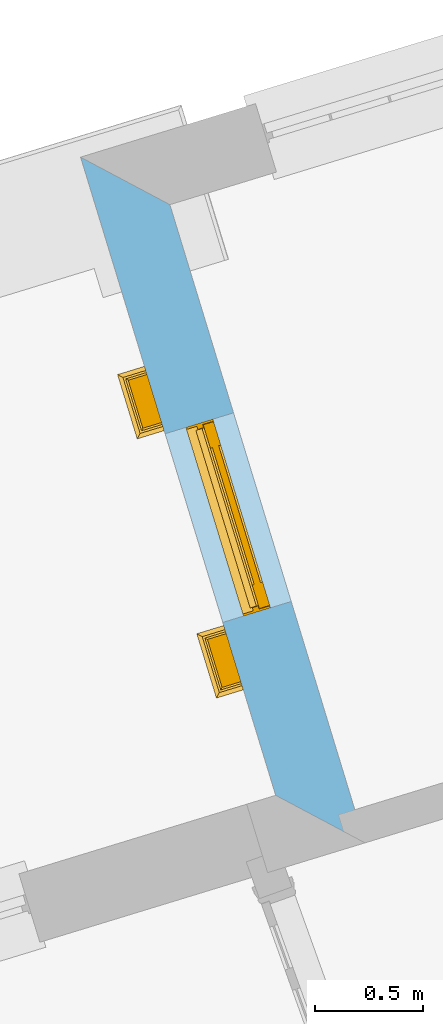
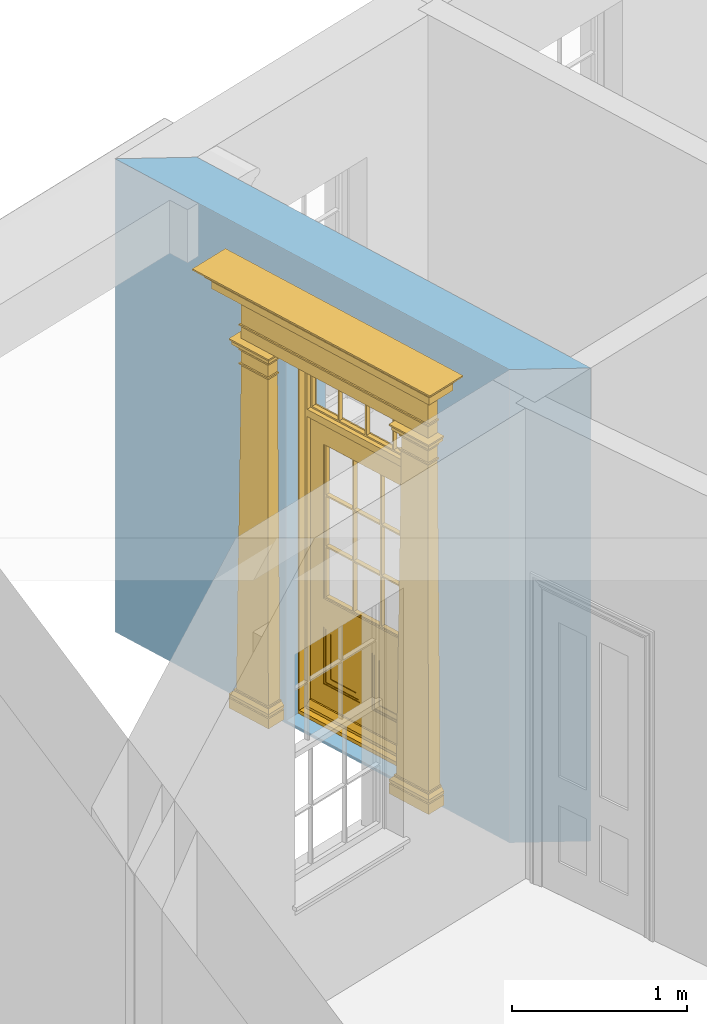
# One storey, part 6 of 10: 1 door, 1 opening, plus 1 element that does not belong to this part.
"""IFC2X3 building model written with IfcOpenShell, lengths in metres."""

from ifc_helpers import new_model, si_unit, frame, origin, place, context, subcontext, project, spatial, polyline, outline, extrude, faceted_brep, material, layer, layer_set, layer_usage, element, fill, save


model = new_model("IFC2X3")

# Units and contexts
model_context = context("Model", 3, world=origin())
body_context = subcontext(model_context, "Body", "Model", "MODEL_VIEW")
ifc_project = project(units=[si_unit("PLANEANGLEUNIT", "RADIAN"), si_unit("MASSUNIT", "GRAM", prefix="KILO"), si_unit("FORCEUNIT", "NEWTON", prefix="KILO"), si_unit("LENGTHUNIT", "METRE")], contexts=[model_context])

# Site, building, storey
site_placement = place(None, origin())
site = spatial("IfcSite", under=ifc_project, at=site_placement, CompositionType="ELEMENT")
building_placement = place(None, origin())
building = spatial("IfcBuilding", under=site, at=building_placement, Name="Building plot-9", CompositionType="ELEMENT")
storey_placement = place(None, frame((0.0, 0.0, 1.0)))
storey = spatial("IfcBuildingStorey", under=building, at=storey_placement, Name="Floor 0", CompositionType="ELEMENT", Elevation=1.0)

# Wall, opening, door
ifc_material = material(Name="Masonry")
ifc_layer = layer(ifc_material, 0.33, ventilated=False)
ifc_layer_set = layer_set([ifc_layer], Name="My Wall")
ifc_layer_usage = layer_usage(ifc_layer_set, "AXIS2", "NEGATIVE", 0.08)
wall_placement = place(storey_placement, origin())
wall = element("IfcWallStandardCase", 1, at=wall_placement, inside=storey, material=ifc_layer_usage, Name="exterior", context=body_context, shape_type="SweptSolid", body=[
    extrude(outline(polyline([(32.1406076281071, 21.1389745200244), (31.7285492158165, 21.3580814912976), (32.6284427963026, 18.4144306229796), (33.0405012085932, 18.1953236517064), (32.1406076281071, 21.1389745200244)])), origin(), (0.0, 0.0, 1.0), 3.3),
])
opening_placement = place(storey_placement, frame((0.0, 0.0, 0.02)))
opening = element("IfcOpeningElement", 2, at=opening_placement, cuts=wall, Name="Opening", ObjectType="Opening", context=body_context, shape_type="SweptSolid", body=[
    extrude(outline(polyline([(32.1185641190768, 20.0822998505183), (32.3846032271463, 19.21205667015), (32.7001859189282, 19.3085323906587), (32.4341468108587, 20.178775571027), (32.1185641190768, 20.0822998505183)])), origin(), (0.0, 0.0, 1.0), 2.545),
])
door_placement = place(storey_placement, frame((32.3576419158813, 20.1553875175704, 0.02), z_axis=(0.0, 0.0, 1.0), x_axis=(0.266039108069485, -0.870243180368337, 0.0)))
door = element("IfcDoor", 3, at=door_placement, inside=storey, Name="house entrance covered", OverallHeight=2.545, OverallWidth=0.91, context=body_context, shape_type="Brep", held_by="IfcProductRepresentation", body=[
    faceted_brep([(-0.305, -0.25, 2.895), (-0.335, -0.25, 2.915), (1.245, -0.25, 2.915), (1.215, -0.25, 2.895), (-0.315, -0.25, 2.895), (-0.335, -0.25, 2.925), (1.245, -0.25, 2.925), (1.225, -0.25, 2.895), (-0.295, -0.25, 2.885), (1.205, -0.25, 2.885), (-0.315, -0.37, 2.895), (-0.305, -0.36, 2.895), (-0.335, -0.39, 2.915), (-0.335, -0.39, 2.925), (-0.395, -0.25, 2.985), (1.305, -0.25, 2.985), (1.245, -0.39, 2.925), (1.245, -0.39, 2.915), (1.225, -0.37, 2.895), (1.215, -0.36, 2.895), (-0.305, -0.25, 2.885), (1.215, -0.25, 2.885), (-0.285, -0.25, 2.875), (1.195, -0.25, 2.875), (-0.305, -0.36, 2.885), (-0.395, -0.45, 2.925), (-0.395, -0.25, 2.925), (-0.405, -0.25, 2.995), (1.315, -0.25, 2.995), (1.305, -0.25, 2.925), (1.305, -0.45, 2.925), (1.215, -0.36, 2.885), (-0.295, -0.35, 2.885), (1.205, -0.35, 2.885), (-0.285, -0.34, 2.875), (1.195, -0.34, 2.875), (-0.275, -0.25, 2.865), (1.185, -0.25, 2.865), (-0.395, -0.45, 2.985), (-0.405, -0.25, 2.985), (-0.415, -0.25, 3.005), (1.325, -0.25, 3.005), (1.315, -0.25, 2.985), (1.305, -0.45, 2.985), (-0.285, -0.25, 2.865), (-0.285, -0.34, 2.865), (1.195, -0.34, 2.865), (1.195, -0.25, 2.865), (-0.275, -0.25, 2.675), (1.185, -0.25, 2.675), (-0.405, -0.46, 2.985), (-0.405, -0.46, 2.995), (-0.415, -0.47, 3.005), (-0.425, -0.25, 3.015), (1.335, -0.25, 3.015), (1.325, -0.47, 3.005), (1.315, -0.46, 2.995), (1.315, -0.46, 2.985), (-0.275, -0.33, 2.865), (1.185, -0.33, 2.865), (-0.275, -0.33, 2.675), (1.185, -0.33, 2.675), (-0.275, -0.25, 2.665), (1.185, -0.25, 2.665), (-0.425, -0.48, 3.005), (-0.425, -0.25, 3.005), (-0.445, -0.25, 3.046), (1.355, -0.25, 3.046), (1.335, -0.25, 3.005), (1.335, -0.48, 3.005), (-0.285, -0.34, 2.675), (-0.285, -0.25, 2.675), (1.195, -0.34, 2.675), (1.195, -0.25, 2.675), (-0.285, -0.25, 2.665), (1.195, -0.25, 2.665), (-0.015, -0.25, 2.575001), (0.925, -0.25, 2.575001), (-0.425, -0.48, 3.015), (-0.435, -0.25, 3.021), (-0.473, -0.25, 3.056), (1.383, -0.25, 3.056), (1.345, -0.25, 3.021), (1.335, -0.48, 3.015), (-0.285, -0.34, 2.665), (1.195, -0.34, 2.665), (-0.275, -0.33, 2.665), (1.185, -0.33, 2.665), (-0.275, -0.25, 2.575001), (1.185, -0.25, 2.575001), (-0.015, -0.33, 2.575001), (0.925, -0.33, 2.575001), (-0.435, -0.49, 3.021), (1.355, -0.5, 3.046), (-0.445, -0.5, 3.046), (1.345, -0.49, 3.021), (-0.473, -0.528, 3.056), (-0.473, -0.25, 3.066), (1.383, -0.25, 3.066), (1.383, -0.528, 3.056), (-0.275, -0.33, 2.575001), (1.185, -0.33, 2.575001), (-0.025, -0.25, 2.565001), (-0.315, -0.25, 2.565001), (1.225, -0.25, 2.565001), (0.935, -0.25, 2.565001), (-0.015, -0.38, 2.565001), (0.925, -0.25, 2.565001), (1.383, -0.528, 3.066), (-0.473, -0.528, 3.066), (-0.325, -0.25, 2.575001), (-0.325, -0.38, 2.575001), (1.235, -0.38, 2.575001), (1.235, -0.25, 2.575001), (-0.015, -0.25, 2.565001), (-0.035, -0.25, 2.535), (-0.305, -0.25, 2.535), (-0.325, -0.25, 2.565001), (1.235, -0.25, 2.565001), (0.945, -0.25, 2.535), (1.215, -0.25, 2.535), (-0.015, -0.38, 2.575001), (0.925, -0.38, 2.575001), (-0.325, -0.38, 2.565001), (1.235, -0.38, 2.565001), (-0.025, -0.37, 2.565001), (-0.025, -0.25, 2.535), (-0.305, -0.25, 2.525), (-0.035, -0.25, 2.525), (-0.315, -0.25, 2.535), (-0.315, -0.37, 2.565001), (1.225, -0.37, 2.565001), (0.935, -0.25, 2.535), (1.225, -0.25, 2.535), (1.215, -0.25, 2.525), (0.945, -0.25, 2.525), (0.935, -0.37, 2.565001), (0.925, -0.38, 2.565001), (-0.025, -0.37, 2.535), (-0.035, -0.36, 2.535), (-0.305, -0.36, 2.525), (-0.305, -0.36, 2.535), (-0.035, -0.36, 2.525), (-0.285, -0.25, 2.505), (-0.055, -0.25, 2.505), (-0.315, -0.37, 2.535), (1.225, -0.37, 2.535), (0.945, -0.36, 2.535), (0.935, -0.37, 2.535), (1.215, -0.36, 2.535), (1.215, -0.36, 2.525), (1.195, -0.25, 2.505), (0.965, -0.25, 2.505), (0.945, -0.36, 2.525), (-0.285, -0.34, 2.505), (-0.055, -0.34, 2.505), (-0.065, -0.25, 2.495), (-0.275, -0.25, 2.495), (1.195, -0.34, 2.505), (1.185, -0.25, 2.495), (0.975, -0.25, 2.495), (0.965, -0.34, 2.505), (-0.285, -0.25, 2.495), (-0.285, -0.34, 2.495), (-0.055, -0.25, 2.495), (-0.055, -0.34, 2.495), (-0.275, -0.25, 2.405), (-0.065, -0.25, 2.405), (1.195, -0.25, 2.495), (1.195, -0.34, 2.495), (1.185, -0.25, 2.405), (0.975, -0.25, 2.405), (0.965, -0.25, 2.495), (0.965, -0.34, 2.495), (-0.275, -0.33, 2.495), (-0.065, -0.33, 2.495), (-0.275, -0.33, 2.405), (-0.065, -0.33, 2.405), (-0.275, -0.25, 2.395), (-0.065, -0.25, 2.395), (1.185, -0.33, 2.495), (1.185, -0.33, 2.405), (1.185, -0.25, 2.395), (0.975, -0.25, 2.395), (0.975, -0.33, 2.405), (0.975, -0.33, 2.495), (-0.285, -0.25, 2.405), (-0.285, -0.34, 2.405), (-0.055, -0.34, 2.405), (-0.055, -0.25, 2.405), (-0.285, -0.25, 2.395), (-0.055, -0.25, 2.395), (-0.295, -0.25, 0.13), (-0.045, -0.25, 0.13), (1.195, -0.34, 2.405), (1.195, -0.25, 2.405), (1.195, -0.25, 2.395), (1.205, -0.25, 0.13), (0.955, -0.25, 0.13), (0.965, -0.25, 2.405), (0.965, -0.25, 2.395), (0.965, -0.34, 2.405), (-0.285, -0.34, 2.395), (-0.055, -0.34, 2.395), (-0.275, -0.33, 2.395), (-0.065, -0.33, 2.395), (-0.295, -0.35, 0.13), (-0.045, -0.35, 0.13), (-0.305, -0.25, 0.12), (-0.035, -0.25, 0.12), (1.195, -0.34, 2.395), (1.185, -0.33, 2.395), (1.205, -0.35, 0.13), (1.215, -0.25, 0.12), (0.945, -0.25, 0.12), (0.955, -0.35, 0.13), (0.975, -0.33, 2.395), (0.965, -0.34, 2.395), (-0.305, -0.25, 0.13), (-0.305, -0.36, 0.13), (-0.035, -0.25, 0.13), (-0.035, -0.36, 0.13), (-0.325, -0.25, 0.1), (-0.015, -0.25, 0.1), (1.215, -0.36, 0.13), (1.215, -0.25, 0.13), (1.235, -0.25, 0.1), (0.925, -0.25, 0.1), (0.945, -0.25, 0.13), (0.945, -0.36, 0.13), (-0.305, -0.36, 0.12), (-0.035, -0.36, 0.12), (-0.325, -0.38, 0.1), (-0.015, -0.38, 0.1), (-0.325, -0.25, 0.08), (-0.015, -0.25, 0.08), (1.215, -0.36, 0.12), (1.235, -0.38, 0.1), (1.235, -0.25, 0.08), (0.925, -0.25, 0.08), (0.925, -0.38, 0.1), (0.945, -0.36, 0.12), (-0.325, -0.38, 0.08), (-0.015, -0.38, 0.08), (-0.315, -0.25, 0.07), (-0.025, -0.25, 0.07), (1.235, -0.38, 0.08), (1.225, -0.25, 0.07), (0.935, -0.25, 0.07), (0.925, -0.38, 0.08), (-0.315, -0.37, 0.07), (-0.025, -0.37, 0.07), (-0.015, -0.25, 0.0), (-0.325, -0.25, 0.0), (1.225, -0.37, 0.07), (1.235, -0.25, 0.0), (0.925, -0.25, 0.0), (0.935, -0.37, 0.07), (-0.325, -0.25, 0.07), (-0.325, -0.38, 0.07), (-0.015, -0.38, 0.07), (-0.015, -0.25, 0.07), (-0.015, -0.38, 0.0), (-0.325, -0.38, 0.0), (1.235, -0.38, 0.07), (1.235, -0.25, 0.07), (1.235, -0.38, 0.0), (0.925, -0.38, 0.0), (0.925, -0.25, 0.07), (0.925, -0.38, 0.07), (0.885, -0.072, 0.025), (0.025, -0.072, 0.025), (0.025, -0.1, 0.025), (0.885, -0.1, 0.025), (0.9, -0.02, 0.025), (0.01, -0.02, 0.025), (0.9, -0.072, 0.025), (0.91, -0.02, 0.0), (0.0, -0.02, 0.0), (0.01, -0.072, 0.025), (0.9, -0.072, 2.07), (0.9, -0.02, 2.07), (0.885, -0.072, 2.055), (0.91, -0.02, 2.08), (0.01, -0.02, 2.07), (0.0, -0.02, 2.08), (0.01, -0.072, 2.07), (0.025, -0.072, 2.055), (0.455, -0.072, 2.07), (0.455, -0.02, 2.07), (0.455, -0.072, 2.055), (0.455, -0.02, 2.08), (0.455, -0.02, 2.105), (0.885, -0.02, 2.105), (0.025, -0.02, 2.105), (0.455, -0.04, 2.105), (0.885, -0.04, 2.105), (0.885, -0.02, 2.52), (0.91, -0.02, 2.545001), (0.025, -0.04, 2.105), (0.0, -0.02, 2.545001), (0.025, -0.02, 2.52), (0.885, -0.04, 2.52), (0.455, -0.02, 2.52), (0.455, -0.02, 2.545001), (0.025, -0.04, 2.52), (0.455, -0.04, 2.52), (0.0, -0.15, 0.0), (0.0, -0.15, 2.08), (0.91, -0.15, 0.0), (0.01, -0.15, 0.025), (0.01, -0.15, 2.08), (0.0, -0.15, 2.545001), (0.9, -0.15, 0.025), (0.91, -0.15, 2.08), (0.01, -0.1, 0.025), (0.01, -0.1, 2.055), (0.01, -0.15, 2.535), (0.455, -0.15, 2.545001), (0.9, -0.15, 2.08), (0.91, -0.15, 2.545001), (0.025, -0.1, 2.055), (0.01, -0.1, 2.105), (0.01, -0.1, 2.535), (0.455, -0.15, 2.535), (0.9, -0.1, 2.055), (0.9, -0.1, 0.025), (0.9, -0.15, 2.535), (0.025, -0.1, 2.105), (0.025, -0.1, 2.52), (0.455, -0.1, 2.535), (0.9, -0.1, 2.105), (0.885, -0.1, 2.055), (0.9, -0.1, 2.535), (0.455, -0.1, 2.055), (0.455, -0.1, 2.105), (0.025, -0.07, 2.105), (0.025, -0.07, 2.52), (0.455, -0.1, 2.52), (0.885, -0.1, 2.105), (0.885, -0.1, 2.52), (0.455, -0.07, 2.105), (0.035, -0.07, 2.51), (0.035, -0.07, 2.115), (0.455, -0.07, 2.52), (0.885, -0.07, 2.52), (0.885, -0.07, 2.105), (0.2475, -0.07, 2.115), (0.2375, -0.07, 2.115), (0.2375, -0.07, 2.51), (0.035, -0.04, 2.51), (0.035, -0.04, 2.115), (0.2475, -0.07, 2.51), (0.875, -0.07, 2.51), (0.875, -0.07, 2.115), (0.6725, -0.07, 2.115), (0.6625, -0.07, 2.115), (0.45, -0.07, 2.115), (0.2375, -0.04, 2.51), (0.2375, -0.04, 2.115), (0.45, -0.07, 2.51), (0.6625, -0.07, 2.51), (0.6725, -0.07, 2.51), (0.875, -0.04, 2.51), (0.875, -0.04, 2.115), (0.46, -0.07, 2.115), (0.45, -0.04, 2.115), (0.2475, -0.04, 2.115), (0.2475, -0.04, 2.51), (0.46, -0.07, 2.51), (0.45, -0.04, 2.51), (0.6725, -0.04, 2.51), (0.6725, -0.04, 2.115), (0.6625, -0.04, 2.51), (0.6625, -0.04, 2.115), (0.46, -0.04, 2.115), (0.46, -0.04, 2.51), (0.898, -0.07, 2.068), (0.898, -0.02, 2.068), (0.012, -0.02, 2.068), (0.012, -0.07, 2.068), (0.898, -0.07, 0.075), (0.898, -0.02, 0.027), (0.012, -0.02, 0.027), (0.012, -0.07, 0.075), (0.898, -0.07, 0.027), (0.012, -0.07, 0.027), (0.883, -0.07, 0.027), (0.883, -0.07, 0.075), (0.027, -0.07, 0.027), (0.027, -0.07, 0.075), (0.883, -0.08, 0.075), (0.883, -0.11, 0.045), (0.027, -0.11, 0.045), (0.027, -0.08, 0.075), (0.027, -0.11, 0.027), (0.883, -0.11, 0.027), (0.745, -0.05, 0.265), (0.545, -0.05, 0.265), (0.545, -0.055, 0.265), (0.745, -0.055, 0.265), (0.745, -0.05, 0.58), (0.545, -0.05, 0.58), (0.545, -0.055, 0.58), (0.515, -0.06, 0.235), (0.775, -0.06, 0.235), (0.745, -0.055, 0.58), (0.515, -0.06, 0.61), (0.515, -0.065, 0.235), (0.775, -0.065, 0.235), (0.775, -0.06, 0.61), (0.515, -0.065, 0.61), (0.785, -0.065, 0.225), (0.505, -0.065, 0.225), (0.775, -0.065, 0.61), (0.505, -0.065, 0.62), (0.785, -0.065, 0.62), (0.505, -0.07, 0.225), (0.785, -0.07, 0.225), (0.505, -0.07, 0.62), (0.785, -0.07, 0.62), (0.405, -0.07, 0.62), (0.405, -0.07, 0.225), (0.785, -0.07, 0.82), (0.125, -0.07, 0.82), (0.405, -0.065, 0.62), (0.405, -0.065, 0.225), (0.125, -0.07, 0.225), (0.785, -0.06, 0.82), (0.125, -0.06, 0.82), (0.125, -0.07, 0.62), (0.125, -0.065, 0.62), (0.395, -0.065, 0.61), (0.395, -0.065, 0.235), (0.125, -0.065, 0.225), (0.785, -0.07, 1.895), (0.558333, -0.06, 0.83), (0.351667, -0.06, 0.83), (0.125, -0.07, 1.895), (0.125, -0.06, 1.895), (0.785, -0.06, 1.895), (0.135, -0.065, 0.61), (0.395, -0.06, 0.61), (0.395, -0.06, 0.235), (0.135, -0.065, 0.235), (0.568333, -0.06, 0.83), (0.558333, -0.03, 0.83), (0.351667, -0.03, 0.83), (0.341667, -0.06, 0.83), (0.135, -0.06, 1.185), (0.135, -0.06, 1.53), (0.775, -0.06, 1.53), (0.775, -0.06, 1.185), (0.135, -0.06, 0.61), (0.365, -0.055, 0.58), (0.365, -0.055, 0.265), (0.135, -0.06, 0.235), (0.568333, -0.06, 1.175), (0.558333, -0.06, 1.175), (0.775, -0.06, 0.83), (0.558333, -0.03, 1.175), (0.785, -0.03, 0.82), (0.125, -0.03, 0.82), (0.351667, -0.03, 1.175), (0.351667, -0.06, 1.175), (0.341667, -0.06, 1.175), (0.135, -0.06, 0.83), (0.135, -0.06, 1.175), (0.135, -0.03, 1.185), (0.135, -0.03, 1.53), (0.135, -0.06, 1.54), (0.351667, -0.06, 1.885), (0.558333, -0.06, 1.885), (0.775, -0.03, 1.53), (0.775, -0.03, 1.185), (0.775, -0.06, 1.175), (0.775, -0.06, 1.54), (0.165, -0.055, 0.58), (0.365, -0.05, 0.58), (0.365, -0.05, 0.265), (0.165, -0.055, 0.265), (0.568333, -0.03, 0.83), (0.568333, -0.03, 1.175), (0.568333, -0.06, 1.185), (0.558333, -0.06, 1.185), (0.775, -0.03, 0.83), (0.785, -0.02, 0.82), (0.125, -0.02, 0.82), (0.341667, -0.03, 0.83), (0.341667, -0.03, 1.175), (0.351667, -0.06, 1.185), (0.341667, -0.06, 1.185), (0.135, -0.03, 0.83), (0.341667, -0.03, 1.185), (0.125, -0.03, 1.895), (0.341667, -0.03, 1.53), (0.341667, -0.06, 1.53), (0.135, -0.06, 1.885), (0.341667, -0.06, 1.54), (0.341667, -0.06, 1.885), (0.558333, -0.03, 1.885), (0.351667, -0.03, 1.885), (0.568333, -0.06, 1.885), (0.785, -0.03, 1.895), (0.568333, -0.03, 1.185), (0.568333, -0.06, 1.53), (0.568333, -0.03, 1.53), (0.568333, -0.06, 1.54), (0.775, -0.06, 1.885), (0.165, -0.05, 0.58), (0.165, -0.05, 0.265), (0.775, -0.03, 1.175), (0.558333, -0.06, 1.53), (0.351667, -0.03, 1.185), (0.558333, -0.03, 1.185), (0.505, -0.02, 0.62), (0.405, -0.02, 0.62), (0.125, -0.02, 1.895), (0.785, -0.02, 1.895), (0.351667, -0.06, 1.53), (0.135, -0.03, 1.175), (0.135, -0.03, 1.54), (0.341667, -0.03, 1.54), (0.135, -0.03, 1.885), (0.351667, -0.06, 1.54), (0.558333, -0.03, 1.54), (0.558333, -0.06, 1.54), (0.351667, -0.03, 1.54), (0.775, -0.03, 1.54), (0.568333, -0.03, 1.54), (0.775, -0.03, 1.885), (0.558333, -0.03, 1.53), (0.405, -0.02, 0.225), (0.505, -0.02, 0.225), (0.125, -0.02, 0.62), (0.785, -0.02, 0.62), (0.351667, -0.03, 1.53), (0.341667, -0.03, 1.885), (0.568333, -0.03, 1.885), (0.405, -0.025, 0.225), (0.405, -0.025, 0.62), (0.505, -0.025, 0.62), (0.505, -0.025, 0.225), (0.125, -0.025, 0.62), (0.785, -0.025, 0.62), (0.395, -0.025, 0.235), (0.395, -0.025, 0.61), (0.125, -0.02, 0.225), (0.125, -0.025, 0.225), (0.515, -0.025, 0.61), (0.515, -0.025, 0.235), (0.785, -0.02, 0.225), (0.785, -0.025, 0.225), (0.135, -0.025, 0.61), (0.775, -0.025, 0.61), (0.135, -0.025, 0.235), (0.395, -0.03, 0.235), (0.395, -0.03, 0.61), (0.515, -0.03, 0.61), (0.515, -0.03, 0.235), (0.775, -0.025, 0.235), (0.135, -0.03, 0.61), (0.775, -0.03, 0.61), (0.135, -0.03, 0.235), (0.365, -0.035, 0.265), (0.365, -0.035, 0.58), (0.545, -0.035, 0.58), (0.545, -0.035, 0.265), (0.775, -0.03, 0.235), (0.165, -0.035, 0.58), (0.745, -0.035, 0.58), (0.165, -0.035, 0.265), (0.365, -0.04, 0.58), (0.365, -0.04, 0.265), (0.545, -0.04, 0.58), (0.545, -0.04, 0.265), (0.745, -0.035, 0.265), (0.165, -0.04, 0.58), (0.745, -0.04, 0.58), (0.165, -0.04, 0.265), (0.745, -0.04, 0.265)], [[[0, 1, 2, 3]], [[0, 4, 1]], [[1, 5, 6, 2]], [[7, 3, 2]], [[8, 0, 3, 9]], [[10, 4, 0, 11]], [[12, 1, 4, 10]], [[1, 12, 13, 5]], [[5, 14, 15, 6]], [[6, 16, 17, 2]], [[7, 18, 19, 3]], [[2, 17, 18, 7]], [[8, 20, 0]], [[21, 9, 3]], [[22, 8, 9, 23]], [[11, 0, 20, 24]], [[10, 11, 19, 18]], [[12, 10, 18, 17]], [[25, 26, 5, 13]], [[13, 12, 17, 16]], [[5, 26, 14]], [[14, 27, 28, 15]], [[29, 6, 15]], [[29, 30, 16, 6]], [[3, 19, 31, 21]], [[24, 20, 8, 32]], [[21, 31, 33, 9]], [[32, 8, 22, 34]], [[9, 33, 35, 23]], [[36, 22, 23, 37]], [[11, 24, 31, 19]], [[38, 14, 26, 25]], [[25, 13, 16, 30]], [[14, 39, 27]], [[27, 40, 41, 28]], [[42, 15, 28]], [[15, 43, 30, 29]], [[24, 32, 33, 31]], [[34, 22, 44, 45]], [[32, 34, 35, 33]], [[23, 35, 46, 47]], [[36, 44, 22]], [[47, 37, 23]], [[48, 36, 37, 49]], [[50, 39, 14, 38]], [[38, 25, 30, 43]], [[51, 27, 39, 50]], [[52, 40, 27, 51]], [[40, 53, 54, 41]], [[41, 55, 56, 28]], [[42, 57, 43, 15]], [[28, 56, 57, 42]], [[45, 44, 36, 58]], [[34, 45, 46, 35]], [[47, 46, 59, 37]], [[60, 58, 36, 48]], [[59, 61, 49, 37]], [[62, 48, 49, 63]], [[50, 38, 43, 57]], [[51, 50, 57, 56]], [[64, 65, 40, 52]], [[52, 51, 56, 55]], [[40, 65, 53]], [[53, 66, 67, 54]], [[68, 41, 54]], [[68, 69, 55, 41]], [[45, 58, 59, 46]], [[58, 60, 61, 59]], [[70, 60, 48, 71]], [[61, 72, 73, 49]], [[71, 48, 62, 74]], [[49, 73, 75, 63]], [[76, 62, 63, 77]], [[78, 53, 65, 64]], [[64, 52, 55, 69]], [[53, 79, 66]], [[66, 80, 81, 67]], [[82, 54, 67]], [[54, 83, 69, 68]], [[60, 70, 72, 61]], [[84, 70, 71, 74]], [[72, 85, 75, 73]], [[86, 84, 74, 62]], [[85, 87, 63, 75]], [[76, 88, 62]], [[89, 77, 63]], [[90, 76, 77, 91]], [[92, 79, 53, 78]], [[93, 94, 92, 95]], [[64, 69, 83, 78]], [[94, 66, 79, 92]], [[80, 66, 94, 96]], [[80, 97, 98, 81]], [[99, 93, 67, 81]], [[82, 95, 83, 54]], [[67, 93, 95, 82]], [[92, 78, 83, 95]], [[70, 84, 85, 72]], [[84, 86, 87, 85]], [[100, 86, 62, 88]], [[87, 101, 89, 63]], [[88, 76, 102, 103]], [[77, 89, 104, 105]], [[76, 90, 106]], [[91, 77, 107]], [[86, 90, 91, 87]], [[108, 98, 97, 109]], [[109, 97, 80, 96]], [[98, 108, 99, 81]], [[86, 100, 90]], [[100, 88, 110, 111]], [[101, 87, 91]], [[89, 101, 112, 113]], [[76, 114, 102]], [[102, 115, 116, 103]], [[110, 88, 103, 117]], [[89, 113, 118, 104]], [[119, 105, 104, 120]], [[107, 77, 105]], [[90, 121, 106]], [[106, 114, 76]], [[107, 122, 91]], [[109, 96, 99, 108]], [[96, 94, 93, 99]], [[111, 121, 90, 100]], [[110, 117, 123, 111]], [[122, 112, 101, 91]], [[118, 113, 112, 124]], [[102, 114, 106, 125]], [[102, 126, 115]], [[127, 116, 115, 128]], [[103, 116, 129]], [[117, 103, 130, 123]], [[104, 118, 124, 131]], [[119, 132, 105]], [[104, 133, 120]], [[120, 134, 135, 119]], [[107, 105, 136, 137]], [[106, 121, 111, 123]], [[107, 137, 122]], [[122, 137, 124, 112]], [[130, 125, 106, 123]], [[126, 102, 125, 138]], [[115, 126, 138, 139]], [[116, 127, 140, 141]], [[128, 115, 139, 142]], [[143, 127, 128, 144]], [[129, 116, 141, 145]], [[103, 129, 145, 130]], [[136, 131, 124, 137]], [[133, 104, 131, 146]], [[132, 119, 147, 148]], [[105, 132, 148, 136]], [[120, 133, 146, 149]], [[134, 120, 149, 150]], [[134, 151, 152, 135]], [[119, 135, 153, 147]], [[138, 125, 130, 145]], [[141, 139, 138, 145]], [[127, 143, 154, 140]], [[142, 139, 141, 140]], [[144, 128, 142, 155]], [[156, 157, 143, 144]], [[136, 148, 146, 131]], [[147, 149, 146, 148]], [[147, 153, 150, 149]], [[151, 134, 150, 158]], [[159, 160, 152, 151]], [[135, 152, 161, 153]], [[143, 162, 163, 154]], [[140, 154, 155, 142]], [[164, 144, 155, 165]], [[166, 157, 156, 167]], [[157, 162, 143]], [[144, 164, 156]], [[158, 150, 153, 161]], [[168, 151, 158, 169]], [[159, 170, 171, 160]], [[172, 152, 160]], [[168, 159, 151]], [[152, 172, 173, 161]], [[174, 163, 162, 157]], [[155, 154, 163, 165]], [[164, 165, 175, 156]], [[157, 166, 176, 174]], [[167, 156, 175, 177]], [[178, 166, 167, 179]], [[158, 161, 173, 169]], [[169, 180, 159, 168]], [[170, 159, 180, 181]], [[170, 182, 183, 171]], [[160, 171, 184, 185]], [[173, 172, 160, 185]], [[174, 175, 165, 163]], [[186, 187, 176, 166]], [[174, 176, 177, 175]], [[177, 188, 189, 167]], [[178, 190, 186, 166]], [[167, 189, 191, 179]], [[192, 178, 179, 193]], [[185, 180, 169, 173]], [[181, 180, 185, 184]], [[194, 195, 170, 181]], [[196, 182, 170, 195]], [[182, 197, 198, 183]], [[199, 171, 183, 200]], [[201, 184, 171, 199]], [[190, 202, 187, 186]], [[177, 176, 187, 188]], [[191, 189, 188, 203]], [[204, 202, 190, 178]], [[191, 203, 205, 179]], [[178, 192, 206, 204]], [[193, 179, 205, 207]], [[208, 192, 193, 209]], [[181, 184, 201, 194]], [[210, 196, 195, 194]], [[210, 211, 182, 196]], [[211, 212, 197, 182]], [[197, 213, 214, 198]], [[183, 198, 215, 216]], [[217, 200, 183, 216]], [[199, 200, 217, 201]], [[202, 203, 188, 187]], [[204, 205, 203, 202]], [[192, 218, 219, 206]], [[204, 206, 207, 205]], [[220, 193, 207, 221]], [[208, 218, 192]], [[193, 220, 209]], [[222, 208, 209, 223]], [[217, 210, 194, 201]], [[216, 211, 210, 217]], [[212, 211, 216, 215]], [[212, 224, 225, 197]], [[225, 213, 197]], [[213, 226, 227, 214]], [[228, 198, 214]], [[198, 228, 229, 215]], [[218, 208, 230, 219]], [[221, 207, 206, 219]], [[209, 220, 221, 231]], [[208, 222, 232, 230]], [[223, 209, 231, 233]], [[234, 222, 223, 235]], [[224, 212, 215, 229]], [[213, 225, 224, 236]], [[226, 213, 236, 237]], [[226, 238, 239, 227]], [[214, 227, 240, 241]], [[228, 214, 241, 229]], [[231, 221, 219, 230]], [[234, 242, 232, 222]], [[233, 231, 230, 232]], [[235, 223, 233, 243]], [[244, 234, 235, 245]], [[229, 241, 236, 224]], [[241, 240, 237, 236]], [[246, 238, 226, 237]], [[238, 247, 248, 239]], [[227, 239, 249, 240]], [[234, 244, 250, 242]], [[243, 233, 232, 242]], [[245, 235, 243, 251]], [[252, 253, 244, 245]], [[240, 249, 246, 237]], [[247, 238, 246, 254]], [[255, 256, 248, 247]], [[239, 248, 257, 249]], [[258, 259, 250, 244]], [[242, 250, 251, 243]], [[251, 260, 261, 245]], [[262, 263, 253, 252]], [[253, 258, 244]], [[245, 261, 252]], [[254, 246, 249, 257]], [[264, 265, 247, 254]], [[266, 267, 256, 255]], [[268, 248, 256]], [[265, 255, 247]], [[269, 257, 248, 268]], [[258, 253, 263, 259]], [[251, 250, 259, 260]], [[252, 261, 260, 262]], [[259, 263, 262, 260]], [[254, 257, 269, 264]], [[255, 265, 264, 266]], [[266, 264, 269, 267]], [[268, 256, 267, 269]], [[270, 271, 272, 273]], [[271, 270, 274, 275]], [[276, 274, 270]], [[274, 277, 278, 275]], [[279, 271, 275]], [[280, 281, 274, 276]], [[276, 270, 282, 280]], [[281, 283, 277, 274]], [[284, 275, 278, 285]], [[286, 287, 271, 279]], [[275, 284, 286, 279]], [[280, 288, 289, 281]], [[282, 290, 288, 280]], [[281, 289, 291, 283]], [[285, 291, 289, 284]], [[286, 288, 290, 287]], [[284, 289, 288, 286]], [[283, 291, 292, 293]], [[294, 292, 291, 285]], [[293, 292, 295, 296]], [[283, 293, 297, 298]], [[299, 295, 292, 294]], [[294, 285, 300, 301]], [[296, 302, 297, 293]], [[297, 303, 304, 298]], [[305, 299, 294, 301]], [[300, 304, 303, 301]], [[302, 306, 303, 297]], [[301, 303, 306, 305]], [[285, 278, 307, 308]], [[309, 307, 278, 277]], [[307, 310, 311, 308]], [[285, 308, 312, 300]], [[307, 309, 313, 310]], [[314, 309, 277, 283]], [[315, 316, 311, 310]], [[312, 308, 311, 317]], [[312, 318, 304, 300]], [[319, 313, 309, 314]], [[310, 313, 273, 272]], [[320, 314, 283, 298]], [[272, 321, 316, 315]], [[322, 311, 316]], [[315, 310, 272]], [[317, 311, 322, 323]], [[317, 324, 318, 312]], [[298, 304, 318, 320]], [[313, 319, 325, 326]], [[327, 319, 314, 320]], [[326, 273, 313]], [[287, 321, 272, 271]], [[322, 316, 321, 328]], [[323, 322, 328, 329]], [[323, 330, 324, 317]], [[320, 318, 324, 327]], [[331, 325, 319]], [[326, 325, 332, 273]], [[333, 331, 319, 327]], [[287, 290, 334, 321]], [[321, 334, 335, 328]], [[336, 337, 329, 328]], [[329, 338, 330, 323]], [[327, 324, 330, 333]], [[339, 332, 325, 331]], [[282, 270, 273, 332]], [[340, 339, 331, 333]], [[332, 334, 290, 282]], [[339, 335, 334, 332]], [[328, 335, 341, 336]], [[342, 337, 336, 343]], [[337, 344, 338, 329]], [[333, 330, 338, 340]], [[339, 340, 345, 346]], [[346, 341, 335, 339]], [[341, 347, 348, 336]], [[342, 349, 337]], [[343, 336, 348]], [[350, 342, 343, 351]], [[349, 352, 344, 337]], [[340, 338, 344, 345]], [[346, 345, 353, 354]], [[355, 356, 341, 346]], [[357, 347, 341]], [[352, 349, 348, 347]], [[349, 342, 350, 358]], [[343, 348, 359, 351]], [[305, 350, 351, 299]], [[360, 344, 352]], [[345, 344, 361, 362]], [[353, 345, 362]], [[353, 363, 364, 354]], [[354, 355, 346]], [[362, 361, 356, 355]], [[365, 341, 356]], [[347, 357, 366, 367]], [[365, 357, 341]], [[358, 359, 348, 349]], [[367, 368, 352, 347]], [[350, 305, 358]], [[351, 359, 299]], [[360, 369, 344]], [[360, 352, 368, 370]], [[369, 361, 344]], [[362, 371, 363, 353]], [[302, 296, 364, 363]], [[372, 355, 354, 364]], [[373, 374, 356, 361]], [[372, 371, 362, 355]], [[365, 356, 374, 375]], [[370, 366, 357, 360]], [[366, 295, 367]], [[369, 360, 357, 365]], [[358, 368, 367, 359]], [[305, 306, 368, 358]], [[359, 367, 295, 299]], [[368, 306, 370]], [[361, 369, 376, 373]], [[363, 371, 302]], [[364, 296, 372]], [[373, 371, 372, 374]], [[374, 295, 375]], [[375, 376, 369, 365]], [[370, 376, 375, 366]], [[375, 295, 366]], [[370, 306, 376]], [[376, 306, 373]], [[371, 373, 306, 302]], [[296, 295, 374, 372]], [[377, 378, 379, 380]], [[381, 382, 378, 377]], [[383, 384, 380, 379]], [[385, 382, 381]], [[383, 386, 384]], [[382, 385, 387]], [[388, 387, 385, 381]], [[386, 383, 389]], [[384, 386, 389, 390]], [[383, 382, 387, 389]], [[391, 392, 387, 388]], [[390, 389, 393, 394]], [[395, 389, 387, 396]], [[396, 387, 392]], [[395, 393, 389]], [[397, 398, 399, 400]], [[397, 401, 402, 398]], [[402, 403, 399, 398]], [[400, 399, 404, 405]], [[406, 401, 397, 400]], [[406, 403, 402, 401]], [[399, 403, 407, 404]], [[405, 404, 408, 409]], [[405, 410, 406, 400]], [[410, 407, 403, 406]], [[404, 407, 411, 408]], [[412, 409, 408, 413]], [[409, 414, 410, 405]], [[414, 411, 407, 410]], [[415, 413, 408, 411]], [[412, 416, 414, 409]], [[412, 413, 417, 418]], [[411, 414, 416, 415]], [[413, 415, 419, 417]], [[418, 420, 416, 412]], [[388, 381, 418, 417]], [[420, 419, 415, 416]], [[417, 419, 421, 422]], [[420, 418, 381]], [[390, 388, 417, 422]], [[419, 420, 423]], [[423, 424, 421, 419]], [[422, 421, 425, 426]], [[420, 381, 377, 423]], [[394, 391, 388, 390]], [[390, 422, 427, 384]], [[428, 429, 424, 423]], [[421, 424, 430]], [[421, 430, 431, 425]], [[432, 433, 426, 425]], [[426, 434, 427, 422]], [[377, 435, 423]], [[393, 392, 391, 394]], [[427, 430, 384]], [[429, 428, 436, 437]], [[438, 424, 429, 439]], [[423, 435, 440, 428]], [[380, 384, 430, 424]], [[434, 431, 430, 427]], [[425, 431, 441, 432]], [[433, 432, 442, 443]], [[444, 434, 426, 433]], [[438, 435, 377, 380]], [[392, 393, 395, 396]], [[445, 436, 428]], [[437, 436, 446, 447]], [[437, 448, 429]], [[438, 380, 424]], [[439, 429, 449, 450]], [[435, 438, 439, 440]], [[451, 452, 428, 440]], [[444, 441, 431, 434]], [[432, 441, 453, 442]], [[443, 442, 454, 455]], [[443, 456, 444, 433]], [[445, 457, 458, 436]], [[445, 428, 459]], [[436, 458, 460, 446]], [[461, 462, 447, 446]], [[447, 463, 464, 437]], [[437, 464, 465, 448]], [[448, 466, 429]], [[467, 449, 429]], [[450, 449, 468, 469]], [[470, 439, 450]], [[440, 439, 471, 472]], [[473, 474, 452, 451]], [[475, 428, 452]], [[476, 451, 440]], [[456, 453, 441, 444]], [[442, 453, 477, 454]], [[454, 478, 479, 455]], [[455, 480, 456, 443]], [[481, 482, 457, 445]], [[458, 457, 483, 484]], [[459, 428, 475]], [[485, 481, 445, 459]], [[460, 458, 464, 463]], [[446, 460, 482, 481]], [[486, 487, 462, 461]], [[462, 488, 447]], [[481, 461, 446]], [[488, 489, 463, 447]], [[465, 464, 490, 491]], [[448, 465, 489, 488]], [[466, 448, 488, 492]], [[466, 467, 429]], [[491, 449, 467, 465]], [[491, 493, 468, 449]], [[469, 468, 462, 494]], [[495, 496, 450, 469]], [[497, 439, 470]], [[498, 470, 450, 496]], [[499, 471, 439]], [[500, 472, 471, 501]], [[502, 440, 472]], [[503, 461, 474, 473]], [[504, 483, 452, 474]], [[505, 506, 473, 451]], [[452, 483, 457, 475]], [[476, 507, 505, 451]], [[476, 440, 508]], [[480, 477, 453, 456]], [[454, 477, 509, 478]], [[479, 478, 509, 510]], [[479, 510, 480, 455]], [[457, 482, 511, 475]], [[512, 484, 483, 505]], [[484, 490, 464, 458]], [[459, 475, 511, 485]], [[481, 485, 461]], [[513, 514, 460, 463]], [[482, 460, 514, 504]], [[515, 516, 487, 486]], [[494, 462, 487, 517]], [[518, 486, 461, 503]], [[462, 492, 488]], [[463, 489, 493, 513]], [[496, 491, 490, 519]], [[489, 465, 467, 520]], [[492, 520, 467, 466]], [[495, 493, 491, 496]], [[489, 520, 468, 493]], [[468, 520, 462]], [[521, 469, 494]], [[495, 469, 521, 522]], [[499, 439, 497]], [[470, 521, 523, 497]], [[498, 522, 521, 470]], [[496, 519, 524, 498]], [[471, 499, 498, 524]], [[525, 526, 472, 500]], [[524, 527, 501, 471]], [[494, 503, 500, 501]], [[502, 508, 440]], [[502, 472, 526, 507]], [[511, 474, 461]], [[528, 503, 473]], [[505, 483, 504, 506]], [[504, 474, 511, 482]], [[529, 528, 473, 506]], [[529, 507, 476, 528]], [[512, 505, 507, 526]], [[528, 476, 508, 530]], [[509, 477, 480, 510]], [[531, 514, 484, 512]], [[484, 514, 513, 490]], [[485, 511, 461]], [[506, 504, 514, 531]], [[532, 516, 515, 533]], [[516, 534, 487]], [[515, 486, 535]], [[487, 379, 517]], [[503, 494, 517, 518]], [[486, 518, 378]], [[492, 462, 520]], [[536, 513, 493, 495]], [[519, 490, 513, 536]], [[494, 523, 521]], [[536, 495, 522, 527]], [[537, 499, 497, 523]], [[522, 498, 499, 537]], [[526, 524, 519, 512]], [[526, 525, 527, 524]], [[529, 525, 500, 538]], [[527, 522, 537, 501]], [[538, 500, 503]], [[501, 537, 494]], [[502, 538, 530, 508]], [[507, 529, 538, 502]], [[528, 530, 503]], [[506, 531, 525, 529]], [[531, 512, 519, 536]], [[539, 540, 516, 532]], [[533, 515, 541, 542]], [[533, 382, 383, 532]], [[540, 543, 534, 516]], [[383, 379, 487, 534]], [[486, 378, 382, 535]], [[544, 541, 515, 535]], [[379, 378, 518, 517]], [[537, 523, 494]], [[527, 525, 531, 536]], [[530, 538, 503]], [[540, 539, 545, 546]], [[532, 547, 548, 539]], [[549, 550, 542, 541]], [[551, 533, 542, 552]], [[533, 551, 382]], [[547, 532, 383]], [[553, 543, 540, 546]], [[547, 534, 543, 548]], [[547, 383, 534]], [[535, 382, 551]], [[544, 554, 549, 541]], [[552, 544, 535, 551]], [[555, 545, 539, 548]], [[556, 557, 546, 545]], [[550, 549, 558, 559]], [[552, 542, 550, 560]], [[548, 543, 553, 555]], [[557, 561, 553, 546]], [[560, 554, 544, 552]], [[562, 558, 549, 554]], [[545, 555, 563, 556]], [[564, 565, 557, 556]], [[559, 558, 566, 567]], [[560, 550, 559, 568]], [[555, 553, 561, 563]], [[565, 569, 561, 557]], [[568, 562, 554, 560]], [[570, 566, 558, 562]], [[556, 563, 571, 564]], [[572, 565, 564, 573]], [[566, 574, 575, 567]], [[568, 559, 567, 576]], [[563, 561, 569, 571]], [[572, 577, 569, 565]], [[576, 570, 562, 568]], [[578, 574, 566, 570]], [[564, 571, 579, 573]], [[579, 577, 572, 573]], [[575, 574, 578, 580]], [[576, 567, 575, 580]], [[569, 577, 579, 571]], [[578, 570, 576, 580]]]),
])
fill(opening, door)

save(model, "model.ifc")
